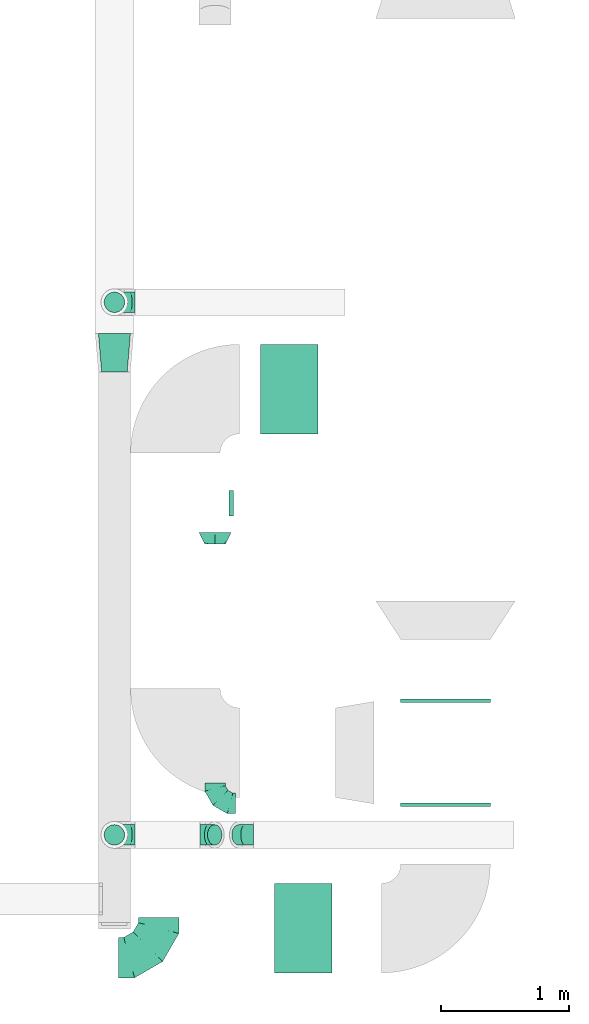
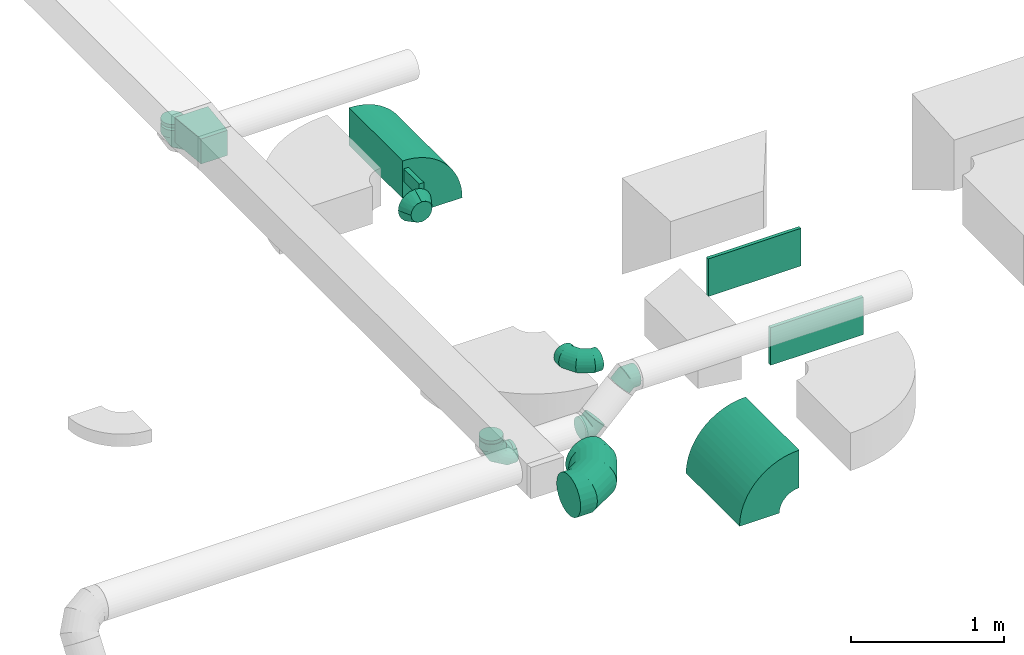
# One storey, part 52 of 62: 15 flow fittings.
"""IFC2X3 building model written with IfcOpenShell, lengths in millimetres."""

from ifc_helpers import new_model, entity, si_unit, converted_unit, derived_unit, direction, frame, frame_2d, origin, origin_2d_with_axis, place, context, subcontext, project, spatial, polyline, circle_curve, parameter, trimmed, segment, composite_curve, rectangle, outline, extrude, faceted_brep, source, transform, mapped, material, type_object, type_shapes, element, save


model = new_model("IFC2X3")

# Units and contexts
model_context = context("Model", 3, precision=0.01, world=origin(), true_north=direction((6.12303176911189e-17, 1.0)))
body_context = subcontext(model_context, "Body", "Model", "MODEL_VIEW")
ifc_project = project(units=[si_unit("LENGTHUNIT", "METRE", prefix="MILLI"), si_unit("AREAUNIT", "SQUARE_METRE"), si_unit("VOLUMEUNIT", "CUBIC_METRE"), converted_unit("PLANEANGLEUNIT", "DEGREE", entity("IfcRatioMeasure", 0.0174532925199433), si_unit("PLANEANGLEUNIT", "RADIAN"), dimensions=[0, 0, 0, 0, 0, 0, 0]), si_unit("MASSUNIT", "GRAM", prefix="KILO"), derived_unit("MASSDENSITYUNIT", [(si_unit("MASSUNIT", "GRAM", prefix="KILO"), 1), (si_unit("LENGTHUNIT", "METRE"), -3)]), derived_unit("MOMENTOFINERTIAUNIT", [(si_unit("LENGTHUNIT", "METRE"), 4)]), si_unit("TIMEUNIT", "SECOND"), si_unit("FREQUENCYUNIT", "HERTZ"), si_unit("THERMODYNAMICTEMPERATUREUNIT", "DEGREE_CELSIUS"), derived_unit("THERMALTRANSMITTANCEUNIT", [(si_unit("MASSUNIT", "GRAM", prefix="KILO"), 1), (si_unit("THERMODYNAMICTEMPERATUREUNIT", "KELVIN"), -1), (si_unit("TIMEUNIT", "SECOND"), -3)]), derived_unit("VOLUMETRICFLOWRATEUNIT", [(si_unit("LENGTHUNIT", "METRE"), 3), (si_unit("TIMEUNIT", "SECOND"), -1)]), derived_unit("MASSFLOWRATEUNIT", [(si_unit("MASSUNIT", "GRAM", prefix="KILO"), 1), (si_unit("TIMEUNIT", "SECOND"), -1)]), derived_unit("ROTATIONALFREQUENCYUNIT", [(si_unit("TIMEUNIT", "SECOND"), -1)]), si_unit("ELECTRICCURRENTUNIT", "AMPERE"), si_unit("ELECTRICVOLTAGEUNIT", "VOLT"), si_unit("POWERUNIT", "WATT"), si_unit("FORCEUNIT", "NEWTON", prefix="KILO"), si_unit("ILLUMINANCEUNIT", "LUX"), si_unit("LUMINOUSFLUXUNIT", "LUMEN"), si_unit("LUMINOUSINTENSITYUNIT", "CANDELA"), derived_unit("USERDEFINED", [(si_unit("MASSUNIT", "GRAM", prefix="KILO"), -1), (si_unit("LENGTHUNIT", "METRE"), -2), (si_unit("TIMEUNIT", "SECOND"), 3), (si_unit("LUMINOUSFLUXUNIT", "LUMEN"), 1)]), derived_unit("LINEARVELOCITYUNIT", [(si_unit("LENGTHUNIT", "METRE"), 1), (si_unit("TIMEUNIT", "SECOND"), -1)]), si_unit("PRESSUREUNIT", "PASCAL"), derived_unit("USERDEFINED", [(si_unit("LENGTHUNIT", "METRE"), -2), (si_unit("MASSUNIT", "GRAM", prefix="KILO"), 1), (si_unit("TIMEUNIT", "SECOND"), -2)]), derived_unit("LINEARFORCEUNIT", [(si_unit("MASSUNIT", "GRAM", prefix="KILO"), 1), (si_unit("LENGTHUNIT", "METRE"), 1), (si_unit("TIMEUNIT", "SECOND"), -2), (si_unit("LENGTHUNIT", "METRE"), -1)]), derived_unit("PLANARFORCEUNIT", [(si_unit("MASSUNIT", "GRAM", prefix="KILO"), 1), (si_unit("LENGTHUNIT", "METRE"), 1), (si_unit("TIMEUNIT", "SECOND"), -2), (si_unit("LENGTHUNIT", "METRE"), -2)])], contexts=[model_context])

# Site, building, storey
site_placement = place(None, origin())
site = spatial("IfcSite", under=ifc_project, at=site_placement, CompositionType="ELEMENT")
building_placement = place(site_placement, origin())
building = spatial("IfcBuilding", under=site, at=building_placement, CompositionType="ELEMENT")
storey_placement = place(building_placement, frame((0.0, 0.0, 24000.0)))
storey = spatial("IfcBuildingStorey", under=building, at=storey_placement, CompositionType="ELEMENT", Elevation=24000.0)

# Flow fittings
ifc_material = material()
duct_fitting_type_1 = type_object("IfcDuctFittingType", PredefinedType="NOTDEFINED", material=ifc_material)
shared_shape_1 = source(origin(), body_context, "Body", "SweptSolid", [
    extrude(outline(polyline([(-159.86, -112.11), (141.18, -112.11), (157.79, 87.2), (-139.1, 137.03), (-159.86, -112.11)])), frame((150.0, 0.0, -100.0), z_axis=(0.0, 0.0, 1.0), x_axis=(0.99654575824488, 0.0830454798537381, 0.0)), (0.0, 0.0, 1.0), 200.0),
])
type_shapes(duct_fitting_type_1, [shared_shape_1])
flow_fitting_1_placement = place(storey_placement, frame((67716.73, 5468.12, 3600.0), z_axis=(0.0, 0.0, 1.0), x_axis=(0.0, -1.0, 0.0)))
element("IfcFlowFitting", 1, at=flow_fitting_1_placement, inside=storey, type_object=duct_fitting_type_1, material=ifc_material, context=body_context, shape_type="MappedRepresentation", body=[
    mapped(shared_shape_1, transform((0.0, 0.0, 0.0), scale=1.0)),
])
duct_fitting_type_2 = type_object("IfcDuctFittingType", PredefinedType="NOTDEFINED", material=ifc_material)
shared_shape_2 = source(origin(), body_context, "Body", "SweptSolid", [
    extrude(rectangle(XDim=26.096000000006, YDim=700.0, at=origin_2d_with_axis()), frame((6.95, 0.0, -150.0)), (0.0, 0.0, 1.0), 300.0),
])
type_shapes(duct_fitting_type_2, [shared_shape_2])
flow_fitting_2_placement = place(storey_placement, frame((70303.15, 1793.41, 3285.0), z_axis=(0.0, 0.0, -1.0), x_axis=(0.0, -1.0, 0.0)))
element("IfcFlowFitting", 2, at=flow_fitting_2_placement, inside=storey, type_object=duct_fitting_type_2, material=ifc_material, context=body_context, shape_type="MappedRepresentation", body=[
    mapped(shared_shape_2, transform((0.0, 0.0, 0.0), scale=1.0)),
])
duct_fitting_type_3 = type_object("IfcDuctFittingType", PredefinedType="NOTDEFINED", material=ifc_material)
shared_shape_3 = source(origin(), body_context, "Body", "SweptSolid", [
    extrude(rectangle(XDim=700.0, YDim=26.0960000000049, at=origin_2d_with_axis()), frame((6.95, 0.0, -150.0), z_axis=(0.0, 0.0, 1.0), x_axis=(0.0, -1.0, 0.0)), (0.0, 0.0, 1.0), 300.0),
])
type_shapes(duct_fitting_type_3, [shared_shape_3])
flow_fitting_3_placement = place(storey_placement, frame((70303.15, 2593.41, 3340.0), z_axis=(0.0, 0.0, -1.0), x_axis=(0.0, 1.0, 0.0)))
element("IfcFlowFitting", 3, at=flow_fitting_3_placement, inside=storey, type_object=duct_fitting_type_3, material=ifc_material, context=body_context, shape_type="MappedRepresentation", body=[
    mapped(shared_shape_3, transform((0.0, 0.0, 0.0), scale=1.0)),
])
duct_fitting_type_4 = type_object("IfcDuctFittingType", PredefinedType="NOTDEFINED", material=ifc_material)
shared_shape_4 = source(origin(), body_context, "Body", "SweptSolid", [
    extrude(rectangle(XDim=36.5316076261198, YDim=200.0, at=origin_2d_with_axis()), frame((1.73, 0.0, -50.0)), (0.0, 0.0, 1.0), 100.0),
])
type_shapes(duct_fitting_type_4, [shared_shape_4])
flow_fitting_4_placement = place(storey_placement, frame((68628.02, 4142.42, 3625.0), z_axis=(0.0, 0.0, -1.0), x_axis=(1.0, 0.0, 0.0)))
element("IfcFlowFitting", 4, at=flow_fitting_4_placement, inside=storey, type_object=duct_fitting_type_4, material=ifc_material, context=body_context, shape_type="MappedRepresentation", body=[
    mapped(shared_shape_4, transform((0.0, 0.0, 0.0), scale=1.0)),
])
duct_fitting_type_5 = type_object("IfcDuctFittingType", PredefinedType="NOTDEFINED", material=ifc_material)
shared_shape_5 = source(origin(), body_context, "Body", "Brep", [
    faceted_brep([(-160.0, 0.0, -80.0), (-160.0, -20.71, -77.27), (-160.0, -40.0, -69.28), (-160.0, -56.57, -56.57), (-160.0, -69.28, -40.0), (-160.0, -77.27, -20.71), (-160.0, -80.0, 0.0), (-160.0, -77.27, 20.71), (-160.0, -69.28, 40.0), (-160.0, -56.57, 56.57), (-160.0, -40.0, 69.28), (-160.0, -20.71, 77.27), (-160.0, 0.0, 80.0), (-160.0, 20.71, 77.27), (-160.0, 40.0, 69.28), (-160.0, 56.57, 56.57), (-160.0, 69.28, 40.0), (-160.0, 77.27, 20.71), (-160.0, 80.0, 0.0), (-160.0, 77.27, -20.71), (-160.0, 69.28, -40.0), (-160.0, 56.57, -56.57), (-160.0, 40.0, -69.28), (-160.0, 20.71, -77.27), (-122.68, 20.71, 77.27), (-127.85, 40.0, 69.28), (-117.13, 0.0, 80.0), (-132.29, 56.57, 56.57), (-137.83, 77.27, 20.71), (-138.56, 80.0, 0.0), (-135.69, 69.28, 40.0), (-135.69, 69.28, -40.0), (-132.29, 56.57, -56.57), (-137.83, 77.27, -20.71), (-122.68, 20.71, -77.27), (-117.13, 0.0, -80.0), (-127.85, 40.0, -69.28), (-111.58, -20.71, -77.27), (-106.41, -40.0, -69.28), (-101.97, -56.57, -56.57), (-98.56, -69.28, -40.0), (-96.42, -77.27, -20.71), (-95.69, -80.0, 0.0), (-96.42, -77.27, 20.71), (-98.56, -69.28, 40.0), (-101.97, -56.57, 56.57), (-106.41, -40.0, 69.28), (-111.58, -20.71, 77.27), (-58.03, 58.03, 77.27), (-72.15, 72.15, 69.28), (-42.87, 42.87, 80.0), (-84.28, 84.28, 56.57), (-93.59, 93.59, 40.0), (-99.44, 99.44, 20.71), (-101.44, 101.44, 0.0), (-99.44, 99.44, -20.71), (-93.59, 93.59, -40.0), (-84.28, 84.28, -56.57), (-58.03, 58.03, -77.27), (-42.87, 42.87, -80.0), (-72.15, 72.15, -69.28), (-27.71, 27.71, -77.27), (-13.59, 13.59, -69.28), (-1.46, 1.46, -56.57), (7.85, -7.85, -40.0), (13.7, -13.7, -20.71), (15.69, -15.69, 0.0), (13.7, -13.7, 20.71), (7.85, -7.85, 40.0), (-1.46, 1.46, 56.57), (-13.59, 13.59, 69.28), (-27.71, 27.71, 77.27), (-20.71, 122.68, 77.27), (-40.0, 127.85, 69.28), (0.0, 117.13, 80.0), (-56.57, 132.29, 56.57), (-69.28, 135.69, 40.0), (-77.27, 137.83, 20.71), (-80.0, 138.56, 0.0), (-77.27, 137.83, -20.71), (-69.28, 135.69, -40.0), (-56.57, 132.29, -56.57), (-20.71, 122.68, -77.27), (0.0, 117.13, -80.0), (-40.0, 127.85, -69.28), (20.71, 111.58, -77.27), (40.0, 106.41, -69.28), (56.57, 101.97, -56.57), (69.28, 98.56, -40.0), (77.27, 96.42, -20.71), (80.0, 95.69, 0.0), (77.27, 96.42, 20.71), (69.28, 98.56, 40.0), (56.57, 101.97, 56.57), (40.0, 106.41, 69.28), (20.71, 111.58, 77.27), (-20.71, 160.0, -77.27), (-40.0, 160.0, -69.28), (-56.57, 160.0, -56.57), (-69.28, 160.0, -40.0), (-77.27, 160.0, -20.71), (-80.0, 160.0, 0.0), (-77.27, 160.0, 20.71), (-69.28, 160.0, 40.0), (-56.57, 160.0, 56.57), (-40.0, 160.0, 69.28), (-20.71, 160.0, 77.27), (0.0, 160.0, 80.0), (20.71, 160.0, 77.27), (40.0, 160.0, 69.28), (56.57, 160.0, 56.57), (69.28, 160.0, 40.0), (77.27, 160.0, 20.71), (80.0, 160.0, 0.0), (77.27, 160.0, -20.71), (69.28, 160.0, -40.0), (56.57, 160.0, -56.57), (40.0, 160.0, -69.28), (20.71, 160.0, -77.27), (0.0, 160.0, -80.0)], [[[0, 1, 2, 3, 4, 5, 6, 7, 8, 9, 10, 11, 12, 13, 14, 15, 16, 17, 18, 19, 20, 21, 22, 23]], [[24, 25, 14, 13]], [[26, 24, 13, 12]], [[14, 25, 27, 15]], [[28, 29, 18, 17]], [[30, 28, 17, 16]], [[15, 27, 30, 16]], [[20, 31, 32, 21]], [[33, 31, 20, 19]], [[18, 29, 33, 19]], [[34, 35, 0, 23]], [[36, 34, 23, 22]], [[32, 36, 22, 21]], [[1, 0, 35, 37]], [[2, 1, 37, 38]], [[3, 2, 38, 39]], [[5, 4, 40, 41]], [[6, 5, 41, 42]], [[39, 40, 4, 3]], [[6, 42, 43, 7]], [[7, 43, 44, 8]], [[8, 44, 45, 9]], [[9, 45, 46, 10]], [[10, 46, 47, 11]], [[26, 12, 11, 47]], [[48, 49, 25, 24]], [[50, 48, 24, 26]], [[27, 25, 49, 51]], [[52, 53, 28, 30]], [[51, 52, 30, 27]], [[29, 28, 53, 54]], [[55, 56, 31, 33]], [[54, 55, 33, 29]], [[32, 31, 56, 57]], [[58, 59, 35, 34]], [[60, 58, 34, 36]], [[57, 60, 36, 32]], [[37, 35, 59, 61]], [[38, 37, 61, 62]], [[39, 38, 62, 63]], [[41, 40, 64, 65]], [[42, 41, 65, 66]], [[63, 64, 40, 39]], [[43, 42, 66, 67]], [[44, 43, 67, 68]], [[68, 69, 45, 44]], [[46, 45, 69, 70]], [[47, 46, 70, 71]], [[26, 47, 71, 50]], [[72, 73, 49, 48]], [[74, 72, 48, 50]], [[51, 49, 73, 75]], [[76, 77, 53, 52]], [[75, 76, 52, 51]], [[54, 53, 77, 78]], [[79, 80, 56, 55]], [[78, 79, 55, 54]], [[57, 56, 80, 81]], [[82, 83, 59, 58]], [[84, 82, 58, 60]], [[81, 84, 60, 57]], [[61, 59, 83, 85]], [[62, 61, 85, 86]], [[63, 62, 86, 87]], [[65, 64, 88, 89]], [[66, 65, 89, 90]], [[87, 88, 64, 63]], [[67, 66, 90, 91]], [[68, 67, 91, 92]], [[92, 93, 69, 68]], [[70, 69, 93, 94]], [[71, 70, 94, 95]], [[50, 71, 95, 74]], [[96, 97, 98, 99, 100, 101, 102, 103, 104, 105, 106, 107, 108, 109, 110, 111, 112, 113, 114, 115, 116, 117, 118, 119]], [[72, 74, 107, 106]], [[73, 72, 106, 105]], [[75, 73, 105, 104]], [[77, 76, 103, 102]], [[78, 77, 102, 101]], [[75, 104, 103, 76]], [[78, 101, 100, 79]], [[79, 100, 99, 80]], [[80, 99, 98, 81]], [[84, 97, 96, 82]], [[82, 96, 119, 83]], [[84, 81, 98, 97]], [[118, 117, 86, 85]], [[119, 118, 85, 83]], [[116, 87, 86, 117]], [[88, 115, 114, 89]], [[89, 114, 113, 90]], [[115, 88, 87, 116]], [[112, 111, 92, 91]], [[113, 112, 91, 90]], [[111, 110, 93, 92]], [[95, 94, 109, 108]], [[74, 95, 108, 107]], [[110, 109, 94, 93]]]),
])
type_shapes(duct_fitting_type_5, [shared_shape_5])
for number, where, z_axis, x_axis in (
    (5, (67716.73, 5711.38, 3300.0), (0.0, 1.0, 0.0), (-1.0, 0.0, 0.0)),
    (6, (68503.02, 1797.41, 3625.0), (0.0, 0.0, 1.0), (0.0, -1.0, 0.0)),
    (7, (67716.73, 1551.4, 3316.59), (0.0, 1.0, 0.0), (-1.0, 0.0, 0.0)),
):
    element("IfcFlowFitting", number, at=place(storey_placement, frame(where, z_axis=z_axis, x_axis=x_axis)), inside=storey, type_object=duct_fitting_type_5, material=ifc_material, context=body_context, shape_type="MappedRepresentation", body=[
        mapped(shared_shape_5, transform((0.0, 0.0, 0.0), scale=1.0)),
    ])
duct_fitting_type_6 = type_object("IfcDuctFittingType", PredefinedType="NOTDEFINED", material=ifc_material)
shared_shape_6 = source(origin(), body_context, "Body", "Brep", [
    faceted_brep([(20.0, 0.0, -80.0), (20.0, 20.71, -77.27), (20.0, 40.0, -69.28), (20.0, 56.57, -56.57), (20.0, 69.28, -40.0), (20.0, 77.27, -20.71), (20.0, 80.0, 0.0), (20.0, 77.27, 20.71), (20.0, 69.28, 40.0), (20.0, 56.57, 56.57), (20.0, 40.0, 69.28), (20.0, 20.71, 77.27), (20.0, 0.0, 80.0), (20.0, -20.71, 77.27), (20.0, -40.0, 69.28), (20.0, -56.57, 56.57), (20.0, -69.28, 40.0), (20.0, -77.27, 20.71), (20.0, -80.0, 0.0), (20.0, -77.27, -20.71), (20.0, -69.28, -40.0), (20.0, -56.57, -56.57), (20.0, -40.0, -69.28), (20.0, -20.71, -77.27), (0.0, 0.0, 80.0), (-6.1, 0.0, 80.0), (-6.1, -20.71, 77.27), (0.0, -20.71, 77.27), (-6.1, -40.0, 69.28), (0.0, -40.0, 69.28), (0.0, -56.57, 56.57), (-6.1, -56.57, 56.57), (0.0, -69.28, 40.0), (-6.1, -69.28, 40.0), (-6.1, -77.27, 20.71), (0.0, -77.27, 20.71), (-6.1, -80.0, 0.0), (0.0, -80.0, 0.0), (-6.1, -77.27, -20.71), (0.0, -77.27, -20.71), (-6.1, -69.28, -40.0), (0.0, -69.28, -40.0), (0.0, -56.57, -56.57), (-6.1, -56.57, -56.57), (0.0, -40.0, -69.28), (-6.1, -40.0, -69.28), (-6.1, -20.71, -77.27), (0.0, -20.71, -77.27), (-6.1, 0.0, -80.0), (0.0, 0.0, -80.0), (-6.1, 20.71, -77.27), (0.0, 20.71, -77.27), (-6.1, 40.0, -69.28), (0.0, 40.0, -69.28), (0.0, 56.57, -56.57), (-6.1, 56.57, -56.57), (0.0, 69.28, -40.0), (-6.1, 69.28, -40.0), (-6.1, 77.27, -20.71), (0.0, 77.27, -20.71), (-6.1, 80.0, 0.0), (0.0, 80.0, 0.0), (-6.1, 77.27, 20.71), (0.0, 77.27, 20.71), (-6.1, 69.28, 40.0), (0.0, 69.28, 40.0), (0.0, 56.57, 56.57), (-6.1, 56.57, 56.57), (0.0, 40.0, 69.28), (-6.1, 40.0, 69.28), (-6.1, 20.71, 77.27), (0.0, 20.71, 77.27)], [[[0, 1, 2, 3, 4, 5, 6, 7, 8, 9, 10, 11, 12, 13, 14, 15, 16, 17, 18, 19, 20, 21, 22, 23]], [[13, 12, 24, 25, 26, 27]], [[14, 13, 27, 26, 28, 29]], [[30, 15, 14, 29, 28, 31]], [[17, 16, 32, 33, 34, 35]], [[18, 17, 35, 34, 36, 37]], [[32, 16, 15, 30, 31, 33]], [[19, 18, 37, 36, 38, 39]], [[20, 19, 39, 38, 40, 41]], [[42, 21, 20, 41, 40, 43]], [[23, 22, 44, 45, 46, 47]], [[0, 23, 47, 46, 48, 49]], [[44, 22, 21, 42, 43, 45]], [[1, 0, 49, 48, 50, 51]], [[2, 1, 51, 50, 52, 53]], [[54, 3, 2, 53, 52, 55]], [[5, 4, 56, 57, 58, 59]], [[6, 5, 59, 58, 60, 61]], [[56, 4, 3, 54, 55, 57]], [[7, 6, 61, 60, 62, 63]], [[8, 7, 63, 62, 64, 65]], [[66, 9, 8, 65, 64, 67]], [[11, 10, 68, 69, 70, 71]], [[12, 11, 71, 70, 25, 24]], [[68, 10, 9, 66, 67, 69]], [[46, 45, 43, 40, 38, 36, 34, 33, 31, 28, 26, 25, 70, 69, 67, 64, 62, 60, 58, 57, 55, 52, 50, 48]]]),
])
type_shapes(duct_fitting_type_6, [shared_shape_6])
for number, where, z_axis, x_axis in (
    (8, (67716.73, 5711.38, 3500.0), (-1.0, 0.0, 0.0), (0.0, 0.0, -1.0)),
    (9, (67716.73, 1551.4, 3500.0), (-1.0, 0.0, 0.0), (0.0, 0.0, -1.0)),
):
    element("IfcFlowFitting", number, at=place(storey_placement, frame(where, z_axis=z_axis, x_axis=x_axis)), inside=storey, type_object=duct_fitting_type_6, material=ifc_material, context=body_context, shape_type="MappedRepresentation", body=[
        mapped(shared_shape_6, transform((0.0, 0.0, 0.0), scale=1.0)),
    ])
duct_fitting_type_7 = type_object("IfcDuctFittingType", PredefinedType="NOTDEFINED", material=ifc_material)
shared_shape_7 = source(origin(), body_context, "Body", "Brep", [
    faceted_brep([(-66.27, 0.0, -80.0), (-66.27, -20.71, -77.27), (-66.27, -40.0, -69.28), (-66.27, -56.57, -56.57), (-66.27, -69.28, -40.0), (-66.27, -77.27, -20.71), (-66.27, -80.0, 0.0), (-66.27, -77.27, 20.71), (-66.27, -69.28, 40.0), (-66.27, -56.57, 56.57), (-66.27, -40.0, 69.28), (-66.27, -20.71, 77.27), (-66.27, 0.0, 80.0), (-66.27, 20.71, 77.27), (-66.27, 40.0, 69.28), (-66.27, 56.57, 56.57), (-66.27, 69.28, 40.0), (-66.27, 77.27, 20.71), (-66.27, 80.0, 0.0), (-66.27, 77.27, -20.71), (-66.27, 69.28, -40.0), (-66.27, 56.57, -56.57), (-66.27, 40.0, -69.28), (-66.27, 20.71, -77.27), (-8.58, 20.71, 77.27), (-16.57, 40.0, 69.28), (0.0, 0.0, 80.0), (-23.43, 56.57, 56.57), (-28.7, 69.28, 40.0), (-32.01, 77.27, 20.71), (-33.14, 80.0, 0.0), (-32.01, 77.27, -20.71), (-28.7, 69.28, -40.0), (-23.43, 56.57, -56.57), (-8.58, 20.71, -77.27), (0.0, 0.0, -80.0), (-16.57, 40.0, -69.28), (8.58, -20.71, -77.27), (16.57, -40.0, -69.28), (23.43, -56.57, -56.57), (28.7, -69.28, -40.0), (32.01, -77.27, -20.71), (33.14, -80.0, 0.0), (32.01, -77.27, 20.71), (28.7, -69.28, 40.0), (23.43, -56.57, 56.57), (16.57, -40.0, 69.28), (8.58, -20.71, 77.27), (46.86, 46.86, 80.0), (32.22, 61.5, 77.27), (18.58, 75.15, 69.28), (6.86, 86.86, 56.57), (-2.13, 95.85, 40.0), (-7.78, 101.5, 20.71), (-9.71, 103.43, 0.0), (-7.78, 101.5, -20.71), (-2.13, 95.85, -40.0), (6.86, 86.86, -56.57), (18.58, 75.15, -69.28), (32.22, 61.5, -77.27), (46.86, 46.86, -80.0), (61.5, 32.22, -77.27), (75.15, 18.58, -69.28), (86.86, 6.86, -56.57), (95.85, -2.13, -40.0), (101.5, -7.78, -20.71), (103.43, -9.71, 0.0), (101.5, -7.78, 20.71), (95.85, -2.13, 40.0), (86.86, 6.86, 56.57), (75.15, 18.58, 69.28), (61.5, 32.22, 77.27)], [[[0, 1, 2, 3, 4, 5, 6, 7, 8, 9, 10, 11, 12, 13, 14, 15, 16, 17, 18, 19, 20, 21, 22, 23]], [[24, 25, 14, 13]], [[26, 24, 13, 12]], [[14, 25, 27, 15]], [[28, 29, 17, 16]], [[28, 16, 15, 27]], [[30, 18, 17, 29]], [[31, 32, 20, 19]], [[30, 31, 19, 18]], [[32, 33, 21, 20]], [[34, 35, 0, 23]], [[36, 34, 23, 22]], [[33, 36, 22, 21]], [[1, 0, 35, 37]], [[2, 1, 37, 38]], [[38, 39, 3, 2]], [[5, 4, 40, 41]], [[6, 5, 41, 42]], [[39, 40, 4, 3]], [[6, 42, 43, 7]], [[7, 43, 44, 8]], [[8, 44, 45, 9]], [[9, 45, 46, 10]], [[10, 46, 47, 11]], [[26, 12, 11, 47]], [[24, 26, 48, 49]], [[25, 24, 49, 50]], [[27, 25, 50, 51]], [[29, 28, 52, 53]], [[30, 29, 53, 54]], [[51, 52, 28, 27]], [[30, 54, 55, 31]], [[31, 55, 56, 32]], [[57, 33, 32, 56]], [[36, 58, 59, 34]], [[34, 59, 60, 35]], [[58, 36, 33, 57]], [[35, 60, 61, 37]], [[37, 61, 62, 38]], [[63, 39, 38, 62]], [[40, 64, 65, 41]], [[41, 65, 66, 42]], [[64, 40, 39, 63]], [[43, 42, 66, 67]], [[44, 43, 67, 68]], [[68, 69, 45, 44]], [[47, 46, 70, 71]], [[26, 47, 71, 48]], [[69, 70, 46, 45]], [[59, 58, 57, 56, 55, 54, 53, 52, 51, 50, 49, 48, 71, 70, 69, 68, 67, 66, 65, 64, 63, 62, 61, 60]]]),
])
type_shapes(duct_fitting_type_7, [shared_shape_7])
for number, where, z_axis, x_axis in (
    (10, (68736.73, 1551.4, 3600.0), (0.0, -1.0, 0.0), (-1.0, 0.0, 0.0)),
    (11, (68453.32, 1551.4, 3316.59), (0.0, 1.0, 0.0), (-0.70710678118654, 0.0, -0.707106781186555)),
):
    element("IfcFlowFitting", number, at=place(storey_placement, frame(where, z_axis=z_axis, x_axis=x_axis)), inside=storey, type_object=duct_fitting_type_7, material=ifc_material, context=body_context, shape_type="MappedRepresentation", body=[
        mapped(shared_shape_7, transform((0.0, 0.0, 0.0), scale=1.0)),
    ])
duct_fitting_type_8 = type_object("IfcDuctFittingType", PredefinedType="NOTDEFINED", material=ifc_material)
shared_shape_8 = source(origin(), body_context, "Body", "Brep", [
    faceted_brep([(-315.0, 0.0, -157.5), (-315.0, -40.76, -152.13), (-315.0, -78.75, -136.4), (-315.0, -111.37, -111.37), (-315.0, -136.4, -78.75), (-315.0, -152.13, -40.76), (-315.0, -157.5, 0.0), (-315.0, -152.13, 40.76), (-315.0, -136.4, 78.75), (-315.0, -111.37, 111.37), (-315.0, -78.75, 136.4), (-315.0, -40.76, 152.13), (-315.0, 0.0, 157.5), (-315.0, 40.76, 152.13), (-315.0, 78.75, 136.4), (-315.0, 111.37, 111.37), (-315.0, 136.4, 78.75), (-315.0, 152.13, 40.76), (-315.0, 157.5, 0.0), (-315.0, 152.13, -40.76), (-315.0, 136.4, -78.75), (-315.0, 111.37, -111.37), (-315.0, 78.75, -136.4), (-315.0, 40.76, -152.13), (-241.52, 40.76, 152.13), (-251.7, 78.75, 136.4), (-230.6, 0.0, 157.5), (-260.44, 111.37, 111.37), (-271.36, 152.13, 40.76), (-272.8, 157.5, 0.0), (-267.14, 136.4, 78.75), (-267.14, 136.4, -78.75), (-260.44, 111.37, -111.37), (-271.36, 152.13, -40.76), (-241.52, 40.76, -152.13), (-230.6, 0.0, -157.5), (-251.7, 78.75, -136.4), (-219.67, -40.76, -152.13), (-209.5, -78.75, -136.4), (-200.75, -111.37, -111.37), (-194.05, -136.4, -78.75), (-189.83, -152.13, -40.76), (-188.39, -157.5, 0.0), (-189.83, -152.13, 40.76), (-194.05, -136.4, 78.75), (-200.75, -111.37, 111.37), (-209.5, -78.75, 136.4), (-219.67, -40.76, 152.13), (-114.25, 114.25, 152.13), (-142.05, 142.05, 136.4), (-84.4, 84.4, 157.5), (-165.93, 165.93, 111.37), (-184.25, 184.25, 78.75), (-195.77, 195.77, 40.76), (-199.7, 199.7, 0.0), (-195.77, 195.77, -40.76), (-184.25, 184.25, -78.75), (-165.93, 165.93, -111.37), (-114.25, 114.25, -152.13), (-84.4, 84.4, -157.5), (-142.05, 142.05, -136.4), (-54.56, 54.56, -152.13), (-26.75, 26.75, -136.4), (-2.88, 2.88, -111.37), (15.45, -15.45, -78.75), (26.97, -26.97, -40.76), (30.89, -30.89, 0.0), (26.97, -26.97, 40.76), (15.45, -15.45, 78.75), (-2.88, 2.88, 111.37), (-26.75, 26.75, 136.4), (-54.56, 54.56, 152.13), (-40.76, 241.52, 152.13), (-78.75, 251.7, 136.4), (0.0, 230.6, 157.5), (-111.37, 260.44, 111.37), (-136.4, 267.14, 78.75), (-152.13, 271.36, 40.76), (-157.5, 272.8, 0.0), (-152.13, 271.36, -40.76), (-136.4, 267.14, -78.75), (-111.37, 260.44, -111.37), (-40.76, 241.52, -152.13), (0.0, 230.6, -157.5), (-78.75, 251.7, -136.4), (40.76, 219.67, -152.13), (78.75, 209.5, -136.4), (111.37, 200.75, -111.37), (136.4, 194.05, -78.75), (152.13, 189.83, -40.76), (157.5, 188.39, 0.0), (152.13, 189.83, 40.76), (136.4, 194.05, 78.75), (111.37, 200.75, 111.37), (78.75, 209.5, 136.4), (40.76, 219.67, 152.13), (-40.76, 315.0, -152.13), (-78.75, 315.0, -136.4), (-111.37, 315.0, -111.37), (-136.4, 315.0, -78.75), (-152.13, 315.0, -40.76), (-157.5, 315.0, 0.0), (-152.13, 315.0, 40.76), (-136.4, 315.0, 78.75), (-111.37, 315.0, 111.37), (-78.75, 315.0, 136.4), (-40.76, 315.0, 152.13), (0.0, 315.0, 157.5), (40.76, 315.0, 152.13), (78.75, 315.0, 136.4), (111.37, 315.0, 111.37), (136.4, 315.0, 78.75), (152.13, 315.0, 40.76), (157.5, 315.0, 0.0), (152.13, 315.0, -40.76), (136.4, 315.0, -78.75), (111.37, 315.0, -111.37), (78.75, 315.0, -136.4), (40.76, 315.0, -152.13), (0.0, 315.0, -157.5)], [[[0, 1, 2, 3, 4, 5, 6, 7, 8, 9, 10, 11, 12, 13, 14, 15, 16, 17, 18, 19, 20, 21, 22, 23]], [[24, 25, 14, 13]], [[26, 24, 13, 12]], [[14, 25, 27, 15]], [[28, 29, 18, 17]], [[30, 28, 17, 16]], [[15, 27, 30, 16]], [[20, 31, 32, 21]], [[33, 31, 20, 19]], [[18, 29, 33, 19]], [[34, 35, 0, 23]], [[36, 34, 23, 22]], [[32, 36, 22, 21]], [[1, 0, 35, 37]], [[2, 1, 37, 38]], [[38, 39, 3, 2]], [[5, 4, 40, 41]], [[6, 5, 41, 42]], [[39, 40, 4, 3]], [[6, 42, 43, 7]], [[7, 43, 44, 8]], [[8, 44, 45, 9]], [[9, 45, 46, 10]], [[10, 46, 47, 11]], [[26, 12, 11, 47]], [[48, 49, 25, 24]], [[50, 48, 24, 26]], [[27, 25, 49, 51]], [[52, 53, 28, 30]], [[51, 52, 30, 27]], [[29, 28, 53, 54]], [[55, 56, 31, 33]], [[54, 55, 33, 29]], [[32, 31, 56, 57]], [[58, 59, 35, 34]], [[60, 58, 34, 36]], [[57, 60, 36, 32]], [[37, 35, 59, 61]], [[38, 37, 61, 62]], [[39, 38, 62, 63]], [[41, 40, 64, 65]], [[42, 41, 65, 66]], [[63, 64, 40, 39]], [[43, 42, 66, 67]], [[44, 43, 67, 68]], [[68, 69, 45, 44]], [[46, 45, 69, 70]], [[47, 46, 70, 71]], [[26, 47, 71, 50]], [[72, 73, 49, 48]], [[74, 72, 48, 50]], [[51, 49, 73, 75]], [[76, 77, 53, 52]], [[75, 76, 52, 51]], [[54, 53, 77, 78]], [[79, 80, 56, 55]], [[78, 79, 55, 54]], [[57, 56, 80, 81]], [[82, 83, 59, 58]], [[84, 82, 58, 60]], [[81, 84, 60, 57]], [[61, 59, 83, 85]], [[62, 61, 85, 86]], [[63, 62, 86, 87]], [[65, 64, 88, 89]], [[66, 65, 89, 90]], [[87, 88, 64, 63]], [[67, 66, 90, 91]], [[68, 67, 91, 92]], [[92, 93, 69, 68]], [[70, 69, 93, 94]], [[71, 70, 94, 95]], [[50, 71, 95, 74]], [[96, 97, 98, 99, 100, 101, 102, 103, 104, 105, 106, 107, 108, 109, 110, 111, 112, 113, 114, 115, 116, 117, 118, 119]], [[106, 105, 73, 72]], [[107, 106, 72, 74]], [[75, 73, 105, 104]], [[77, 76, 103, 102]], [[78, 77, 102, 101]], [[104, 103, 76, 75]], [[78, 101, 100, 79]], [[79, 100, 99, 80]], [[98, 81, 80, 99]], [[84, 97, 96, 82]], [[82, 96, 119, 83]], [[97, 84, 81, 98]], [[83, 119, 118, 85]], [[85, 118, 117, 86]], [[116, 87, 86, 117]], [[88, 115, 114, 89]], [[89, 114, 113, 90]], [[115, 88, 87, 116]], [[91, 90, 113, 112]], [[92, 91, 112, 111]], [[111, 110, 93, 92]], [[95, 94, 109, 108]], [[74, 95, 108, 107]], [[110, 109, 94, 93]]]),
])
type_shapes(duct_fitting_type_8, [shared_shape_8])
flow_fitting_5_placement = place(storey_placement, frame((68062.74, 593.17, 3590.0)))
element("IfcFlowFitting", 12, at=flow_fitting_5_placement, inside=storey, type_object=duct_fitting_type_8, material=ifc_material, context=body_context, shape_type="MappedRepresentation", body=[
    mapped(shared_shape_8, transform((0.0, 0.0, 0.0), scale=1.0)),
])
duct_fitting_type_9 = type_object("IfcDuctFittingType", PredefinedType="NOTDEFINED", material=ifc_material)
shared_shape_9 = source(origin(), body_context, "Body", "Brep", [
    faceted_brep([(90.0, -73.47, -101.13), (90.0, -38.63, -118.88), (90.0, 0.0, -125.0), (90.0, 38.63, -118.88), (90.0, 73.47, -101.13), (90.0, 101.13, -73.47), (90.0, 118.88, -38.63), (90.0, 125.0, 0.0), (90.0, 118.88, 38.63), (90.0, 101.13, 73.47), (90.0, 73.47, 101.13), (90.0, 38.63, 118.88), (90.0, 0.0, 125.0), (90.0, -38.63, 118.88), (90.0, -73.47, 101.13), (90.0, -101.13, 73.47), (90.0, -118.88, 38.63), (90.0, -125.0, 0.0), (90.0, -118.88, -38.63), (90.0, -101.13, -73.47), (0.0, -30.61, -73.91), (0.0, -43.59, -65.24), (0.0, -56.57, -56.57), (0.0, -65.24, -43.59), (0.0, -73.91, -30.61), (0.0, -76.96, -15.31), (0.0, -80.0, 0.0), (0.0, -76.96, 15.31), (0.0, -73.91, 30.61), (0.0, -65.24, 43.59), (0.0, -56.57, 56.57), (0.0, -43.59, 65.24), (0.0, -30.61, 73.91), (0.0, -15.31, 76.96), (0.0, 0.0, 80.0), (0.0, 15.31, 76.96), (0.0, 30.61, 73.91), (0.0, 43.59, 65.24), (0.0, 56.57, 56.57), (0.0, 65.24, 43.59), (0.0, 73.91, 30.61), (0.0, 76.96, 15.31), (0.0, 80.0, 0.0), (0.0, 76.96, -15.31), (0.0, 73.91, -30.61), (0.0, 65.24, -43.59), (0.0, 56.57, -56.57), (0.0, 43.59, -65.24), (0.0, 30.61, -73.91), (0.0, 15.31, -76.96), (0.0, 0.0, -80.0), (0.0, -15.31, -76.96)], [[[0, 1, 2, 3, 4, 5, 6, 7, 8, 9, 10, 11, 12, 13, 14, 15, 16, 17, 18, 19]], [[20, 21, 22, 23, 24, 25, 26, 27, 28, 29, 30, 31, 32, 33, 34, 35, 36, 37, 38, 39, 40, 41, 42, 43, 44, 45, 46, 47, 48, 49, 50, 51]], [[7, 41, 8]], [[41, 40, 8]], [[40, 9, 8]], [[11, 36, 35]], [[41, 7, 42]], [[9, 40, 39, 38]], [[10, 38, 37, 36]], [[12, 35, 34]], [[11, 10, 36]], [[12, 11, 35]], [[38, 10, 9]], [[12, 33, 13]], [[33, 32, 13]], [[32, 14, 13]], [[16, 28, 27]], [[33, 12, 34]], [[14, 32, 31, 30]], [[15, 30, 29, 28]], [[17, 27, 26]], [[16, 15, 28]], [[17, 16, 27]], [[30, 15, 14]], [[17, 25, 18]], [[25, 24, 18]], [[24, 19, 18]], [[1, 20, 51]], [[25, 17, 26]], [[19, 24, 23, 22]], [[0, 22, 21, 20]], [[2, 51, 50]], [[1, 0, 20]], [[2, 1, 51]], [[22, 0, 19]], [[2, 49, 3]], [[49, 48, 3]], [[48, 4, 3]], [[6, 44, 43]], [[49, 2, 50]], [[4, 48, 47, 46]], [[5, 46, 45, 44]], [[7, 43, 42]], [[6, 5, 44]], [[7, 6, 43]], [[46, 5, 4]]]),
])
type_shapes(duct_fitting_type_9, [shared_shape_9])
flow_fitting_6_placement = place(storey_placement, frame((68503.02, 3822.41, 3625.0), z_axis=(0.0, 0.0, 1.0), x_axis=(0.0, 1.0, 0.0)))
element("IfcFlowFitting", 13, at=flow_fitting_6_placement, inside=storey, type_object=duct_fitting_type_9, material=ifc_material, context=body_context, shape_type="MappedRepresentation", body=[
    mapped(shared_shape_9, transform((0.0, 0.0, 0.0), scale=1.0)),
])
duct_fitting_type_10 = type_object("IfcDuctFittingType", PredefinedType="NOTDEFINED", material=ifc_material)
shared_shape_10 = source(origin(), body_context, "Body", "SweptSolid", [
    extrude(outline(composite_curve([segment(polyline([(-300.0, -150.0), (0.0, -150.0)]), True, "CONTINUOUS"), segment(trimmed(circle_curve(frame_2d((150.0, -150.0), x_axis=(0.0, 1.0)), 150.0), [parameter(0.0)], [parameter(90.0)], True, "PARAMETER"), False, "CONTINUOUS"), segment(polyline([(150.0, 0.0), (150.0, 300.0)]), True, "CONTINUOUS"), segment(trimmed(circle_curve(frame_2d((150.0, -150.0), x_axis=(0.0, 1.0)), 450.0), [parameter(0.0)], [parameter(90.0000000000001)], True, "PARAMETER"), True, "CONTINUOUS")], self_intersect=False)), frame((-150.0, 150.0, -350.0), z_axis=(0.0, 0.0, 1.0), x_axis=(-1.0, 0.0, 0.0)), (0.0, 0.0, 1.0), 700.0),
])
type_shapes(duct_fitting_type_10, [shared_shape_10])
for number, where, z_axis, x_axis in (
    (14, (69156.97, 5033.42, 3235.0), (0.0, 1.0, 0.0), (1.0, 0.0, 0.0)),
    (15, (69118.15, 823.12, 3285.0), (0.0, -1.0, 0.0), (-1.0, 0.0, 0.0)),
):
    element("IfcFlowFitting", number, at=place(storey_placement, frame(where, z_axis=z_axis, x_axis=x_axis)), inside=storey, type_object=duct_fitting_type_10, material=ifc_material, context=body_context, shape_type="MappedRepresentation", body=[
        mapped(shared_shape_10, transform((0.0, 0.0, 0.0), scale=1.0)),
    ])

save(model, "model.ifc")
